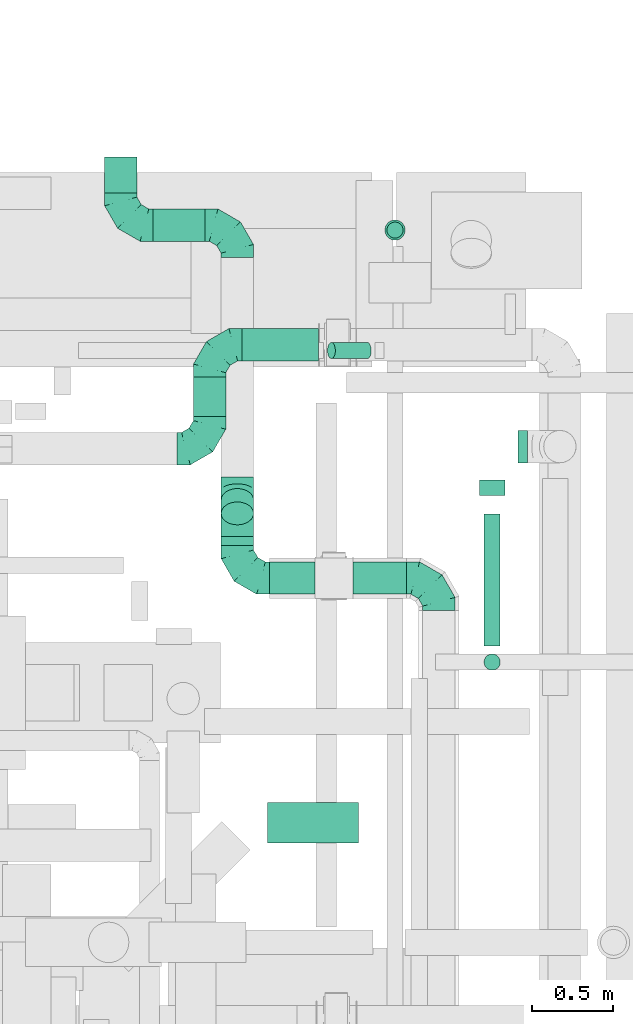
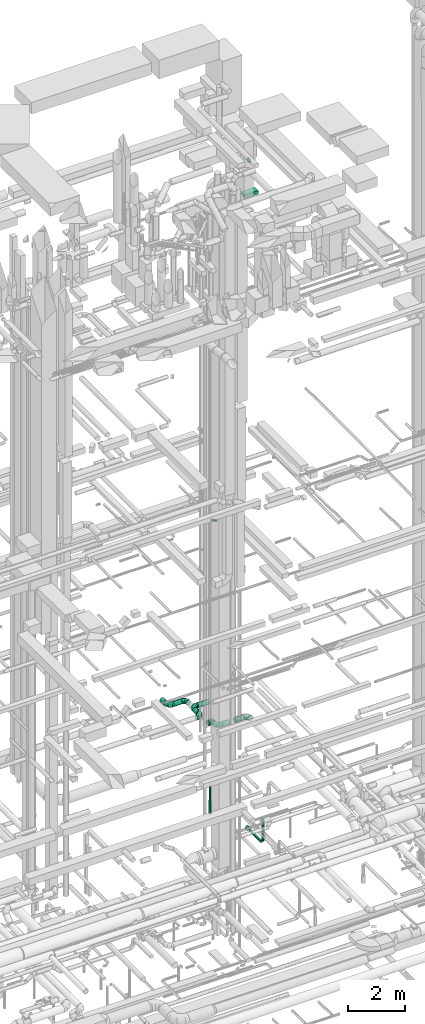
# One storey, part 292 of 337: 16 flow segments, 8 flow fittings.
"""IFC2X3 building model written with IfcOpenShell, lengths in millimetres."""

from ifc_helpers import new_model, entity, si_unit, converted_unit, derived_unit, direction, frame, origin, origin_2d_with_axis, place, context, subcontext, project, spatial, rectangle, circle, extrude, faceted_brep, source, transform, mapped, material, type_object, type_shapes, element, save


model = new_model("IFC2X3")

# Units and contexts
model_context = context("Model", 3, precision=0.01, world=origin(), true_north=direction((6.12303176911189e-17, 1.0)))
body_context = subcontext(model_context, "Body", "Model", "MODEL_VIEW")
ifc_project = project(units=[si_unit("LENGTHUNIT", "METRE", prefix="MILLI"), si_unit("AREAUNIT", "SQUARE_METRE"), si_unit("VOLUMEUNIT", "CUBIC_METRE"), converted_unit("PLANEANGLEUNIT", "DEGREE", entity("IfcRatioMeasure", 0.0174532925199433), si_unit("PLANEANGLEUNIT", "RADIAN"), dimensions=[0, 0, 0, 0, 0, 0, 0]), si_unit("MASSUNIT", "GRAM", prefix="KILO"), derived_unit("MASSDENSITYUNIT", [(si_unit("MASSUNIT", "GRAM", prefix="KILO"), 1), (si_unit("LENGTHUNIT", "METRE"), -3)]), derived_unit("MOMENTOFINERTIAUNIT", [(si_unit("LENGTHUNIT", "METRE"), 4)]), si_unit("TIMEUNIT", "SECOND"), si_unit("FREQUENCYUNIT", "HERTZ"), si_unit("THERMODYNAMICTEMPERATUREUNIT", "DEGREE_CELSIUS"), derived_unit("THERMALTRANSMITTANCEUNIT", [(si_unit("MASSUNIT", "GRAM", prefix="KILO"), 1), (si_unit("THERMODYNAMICTEMPERATUREUNIT", "KELVIN"), -1), (si_unit("TIMEUNIT", "SECOND"), -3)]), derived_unit("VOLUMETRICFLOWRATEUNIT", [(si_unit("LENGTHUNIT", "METRE"), 3), (si_unit("TIMEUNIT", "SECOND"), -1)]), derived_unit("MASSFLOWRATEUNIT", [(si_unit("MASSUNIT", "GRAM", prefix="KILO"), 1), (si_unit("TIMEUNIT", "SECOND"), -1)]), derived_unit("ROTATIONALFREQUENCYUNIT", [(si_unit("TIMEUNIT", "SECOND"), -1)]), si_unit("ELECTRICCURRENTUNIT", "AMPERE"), si_unit("ELECTRICVOLTAGEUNIT", "VOLT"), si_unit("POWERUNIT", "WATT"), si_unit("FORCEUNIT", "NEWTON", prefix="KILO"), si_unit("ILLUMINANCEUNIT", "LUX"), si_unit("LUMINOUSFLUXUNIT", "LUMEN"), si_unit("LUMINOUSINTENSITYUNIT", "CANDELA"), derived_unit("USERDEFINED", [(si_unit("MASSUNIT", "GRAM", prefix="KILO"), -1), (si_unit("LENGTHUNIT", "METRE"), -2), (si_unit("TIMEUNIT", "SECOND"), 3), (si_unit("LUMINOUSFLUXUNIT", "LUMEN"), 1)]), derived_unit("LINEARVELOCITYUNIT", [(si_unit("LENGTHUNIT", "METRE"), 1), (si_unit("TIMEUNIT", "SECOND"), -1)]), si_unit("PRESSUREUNIT", "PASCAL"), derived_unit("USERDEFINED", [(si_unit("LENGTHUNIT", "METRE"), -2), (si_unit("MASSUNIT", "GRAM", prefix="KILO"), 1), (si_unit("TIMEUNIT", "SECOND"), -2)]), derived_unit("LINEARFORCEUNIT", [(si_unit("MASSUNIT", "GRAM", prefix="KILO"), 1), (si_unit("LENGTHUNIT", "METRE"), 1), (si_unit("TIMEUNIT", "SECOND"), -2), (si_unit("LENGTHUNIT", "METRE"), -1)]), derived_unit("PLANARFORCEUNIT", [(si_unit("MASSUNIT", "GRAM", prefix="KILO"), 1), (si_unit("LENGTHUNIT", "METRE"), 1), (si_unit("TIMEUNIT", "SECOND"), -2), (si_unit("LENGTHUNIT", "METRE"), -2)])], contexts=[model_context])

# Site, building, storey
site_placement = place(None, origin())
site = spatial("IfcSite", under=ifc_project, at=site_placement, CompositionType="ELEMENT")
building_placement = place(site_placement, origin())
building = spatial("IfcBuilding", under=site, at=building_placement, CompositionType="ELEMENT")
storey_placement = place(building_placement, origin())
storey = spatial("IfcBuildingStorey", under=building, at=storey_placement, CompositionType="ELEMENT", Elevation=0.0)

# Flow segments
duct_segment_type_1 = type_object("IfcDuctSegmentType", PredefinedType="NOTDEFINED")
flow_segment_1_placement = place(storey_placement, frame((62576.39, 15963.68, 27135.0)))
element("IfcFlowSegment", 1, at=flow_segment_1_placement, inside=storey, type_object=duct_segment_type_1, context=body_context, shape_type="SweptSolid", body=[
    extrude(rectangle(XDim=561.091270347412, YDim=249.999999999999, at=origin_2d_with_axis()), frame((280.55, 125.0, 0.0)), (0.0, 0.0, 1.0), 150.000000000001),
])
duct_segment_type_2 = type_object("IfcDuctSegmentType", PredefinedType="NOTDEFINED")
flow_segment_2_placement = place(storey_placement, frame((63312.58, 19696.98, -1203.72)))
element("IfcFlowSegment", 2, at=flow_segment_2_placement, inside=storey, type_object=duct_segment_type_2, context=body_context, shape_type="SweptSolid", body=[
    extrude(circle(Radius=50.0, at=origin_2d_with_axis()), frame((51.6, 51.6, 0.0)), (0.0, 0.0, 1.0), 583.718429676785),
])
flow_segment_3_placement = place(storey_placement, frame((63300.08, 19684.48, -1800.0)))
element("IfcFlowSegment", 3, at=flow_segment_3_placement, inside=storey, type_object=duct_segment_type_2, context=body_context, shape_type="SweptSolid", body=[
    extrude(circle(Radius=62.5, at=origin_2d_with_axis()), frame((64.1, 64.1, 0.0), z_axis=(0.0, 0.0, 1.0), x_axis=(0.0, 1.0, 0.0)), (0.0, 0.0, 1.0), 549.581570323214),
])
flow_segment_4_placement = place(storey_placement, frame((63912.49, 17028.51, -1553.0)))
element("IfcFlowSegment", 4, at=flow_segment_4_placement, inside=storey, type_object=duct_segment_type_2, context=body_context, shape_type="SweptSolid", body=[
    extrude(circle(Radius=50.0, at=origin_2d_with_axis()), frame((51.6, 51.6, 0.0), z_axis=(0.0, 0.0, 1.0), x_axis=(0.0, -1.0, 0.0)), (0.0, 0.0, 1.0), 932.999999999999),
])
flow_segment_5_placement = place(storey_placement, frame((63912.49, 17180.11, -1704.6)))
element("IfcFlowSegment", 5, at=flow_segment_5_placement, inside=storey, type_object=duct_segment_type_2, context=body_context, shape_type="SweptSolid", body=[
    extrude(circle(Radius=50.0, at=origin_2d_with_axis()), frame((51.6, 0.0, 51.6), z_axis=(0.0, 1.0, 0.0), x_axis=(1.0, 0.0, 0.0)), (0.0, 0.0, 1.0), 816.003630002967),
])
flow_segment_6_placement = place(storey_placement, frame((63882.49, 18108.11, -1734.6)))
element("IfcFlowSegment", 6, at=flow_segment_6_placement, inside=storey, type_object=duct_segment_type_2, context=body_context, shape_type="SweptSolid", body=[
    extrude(circle(Radius=80.0, at=origin_2d_with_axis()), frame((81.6, 0.0, 81.6), z_axis=(0.0, 1.0, 0.0), x_axis=(1.0, 0.0, 0.0)), (0.0, 0.0, 1.0), 96.9963699970336),
])
flow_segment_7_placement = place(storey_placement, frame((62945.62, 18952.95, 11219.34)))
element("IfcFlowSegment", 7, at=flow_segment_7_placement, inside=storey, type_object=duct_segment_type_2, context=body_context, shape_type="SweptSolid", body=[
    extrude(circle(Radius=50.0, at=origin_2d_with_axis()), frame((247.36, 51.6, 45.33), z_axis=(-0.874619707139393, 0.0, 0.484809620246342), x_axis=(0.0, -1.0, 0.0)), (0.0, 0.0, 1.0), 253.276483128838),
])
flow_segment_8_placement = place(storey_placement, frame((62590.14, 17497.79, 3498.4)))
element("IfcFlowSegment", 8, at=flow_segment_8_placement, inside=storey, type_object=duct_segment_type_2, context=body_context, shape_type="SweptSolid", body=[
    extrude(circle(Radius=100.0, at=origin_2d_with_axis()), frame((0.0, 101.6, 101.6), z_axis=(1.0, 0.0, 0.0), x_axis=(0.0, 1.0, 0.0)), (0.0, 0.0, 1.0), 279.856301087674),
])
flow_segment_9_placement = place(storey_placement, frame((64122.65, 18309.88, 26648.4)))
element("IfcFlowSegment", 9, at=flow_segment_9_placement, inside=storey, type_object=duct_segment_type_2, context=body_context, shape_type="SweptSolid", body=[
    extrude(circle(Radius=100.0, at=origin_2d_with_axis()), frame((0.0, 101.6, 101.6), z_axis=(1.0, 0.0, 0.0), x_axis=(0.0, 1.0, 0.0)), (0.0, 0.0, 1.0), 60.0000000000123),
])
flow_segment_10_placement = place(storey_placement, frame((62418.88, 18939.21, 3498.4)))
element("IfcFlowSegment", 10, at=flow_segment_10_placement, inside=storey, type_object=duct_segment_type_2, context=body_context, shape_type="SweptSolid", body=[
    extrude(circle(Radius=100.0, at=origin_2d_with_axis()), frame((0.0, 101.6, 101.6), z_axis=(1.0, 0.0, 0.0), x_axis=(0.0, 1.0, 0.0)), (0.0, 0.0, 1.0), 473.615952508406),
])
flow_segment_11_placement = place(storey_placement, frame((62117.29, 18598.74, 3498.4)))
element("IfcFlowSegment", 11, at=flow_segment_11_placement, inside=storey, type_object=duct_segment_type_2, context=body_context, shape_type="SweptSolid", body=[
    extrude(circle(Radius=100.0, at=origin_2d_with_axis()), frame((101.6, 0.0, 101.6), z_axis=(0.0, 1.0, 0.0), x_axis=(-1.0, 0.0, 0.0)), (0.0, 0.0, 1.0), 242.064865424008),
])
flow_segment_12_placement = place(storey_placement, frame((62288.55, 17799.39, 3498.4)))
element("IfcFlowSegment", 12, at=flow_segment_12_placement, inside=storey, type_object=duct_segment_type_2, context=body_context, shape_type="SweptSolid", body=[
    extrude(circle(Radius=100.0, at=origin_2d_with_axis()), frame((101.6, 0.0, 101.6), z_axis=(0.0, 1.0, 0.0), x_axis=(1.0, 0.0, 0.0)), (0.0, 0.0, 1.0), 57.8773021998964),
])
flow_segment_13_placement = place(storey_placement, frame((62288.55, 17926.38, 3386.27)))
element("IfcFlowSegment", 13, at=flow_segment_13_placement, inside=storey, type_object=duct_segment_type_2, context=body_context, shape_type="SweptSolid", body=[
    extrude(circle(Radius=100.0, at=origin_2d_with_axis()), frame((101.6, 155.15, 72.31), z_axis=(0.0, -0.707106792500204, 0.707106769872891), x_axis=(1.0, 0.0, 0.0)), (0.0, 0.0, 1.0), 117.157295799914),
])
flow_segment_14_placement = place(storey_placement, frame((61870.14, 19677.79, 3298.4)))
element("IfcFlowSegment", 14, at=flow_segment_14_placement, inside=storey, type_object=duct_segment_type_2, context=body_context, shape_type="SweptSolid", body=[
    extrude(circle(Radius=100.0, at=origin_2d_with_axis()), frame((0.0, 101.6, 101.6), z_axis=(1.0, 0.0, 0.0), x_axis=(0.0, 1.0, 0.0)), (0.0, 0.0, 1.0), 319.999999999997),
])
flow_segment_15_placement = place(storey_placement, frame((61568.55, 19979.39, 3298.4)))
element("IfcFlowSegment", 15, at=flow_segment_15_placement, inside=storey, type_object=duct_segment_type_2, context=body_context, shape_type="SweptSolid", body=[
    extrude(circle(Radius=100.0, at=origin_2d_with_axis()), frame((101.6, 0.0, 101.6), z_axis=(0.0, 1.0, 0.0), x_axis=(1.0, 0.0, 0.0)), (0.0, 0.0, 1.0), 220.000000000015),
])
flow_segment_16_placement = place(storey_placement, frame((63105.0, 17497.79, 3498.4)))
element("IfcFlowSegment", 16, at=flow_segment_16_placement, inside=storey, type_object=duct_segment_type_2, context=body_context, shape_type="SweptSolid", body=[
    extrude(circle(Radius=100.0, at=origin_2d_with_axis()), frame((0.0, 101.6, 101.6), z_axis=(1.0, 0.0, 0.0), x_axis=(0.0, 1.0, 0.0)), (0.0, 0.0, 1.0), 330.444555311786),
])

# Flow fittings
ifc_material = material()
duct_fitting_type_1 = type_object("IfcDuctFittingType", PredefinedType="NOTDEFINED", material=ifc_material)
shared_shape_1 = source(origin(), body_context, "Body", "Brep", [
    faceted_brep([(-200.0, 0.0, -100.0), (-200.0, -25.88, -96.59), (-200.0, -50.0, -86.6), (-200.0, -70.71, -70.71), (-200.0, -86.6, -50.0), (-200.0, -96.59, -25.88), (-200.0, -100.0, 0.0), (-200.0, -96.59, 25.88), (-200.0, -86.6, 50.0), (-200.0, -70.71, 70.71), (-200.0, -50.0, 86.6), (-200.0, -25.88, 96.59), (-200.0, 0.0, 100.0), (-200.0, 25.88, 96.59), (-200.0, 50.0, 86.6), (-200.0, 70.71, 70.71), (-200.0, 86.6, 50.0), (-200.0, 96.59, 25.88), (-200.0, 100.0, 0.0), (-200.0, 96.59, -25.88), (-200.0, 86.6, -50.0), (-200.0, 70.71, -70.71), (-200.0, 50.0, -86.6), (-200.0, 25.88, -96.59), (-153.35, 25.88, 96.59), (-159.81, 50.0, 86.6), (-146.41, 0.0, 100.0), (-165.36, 70.71, 70.71), (-172.29, 96.59, 25.88), (-173.21, 100.0, 0.0), (-169.62, 86.6, 50.0), (-169.62, 86.6, -50.0), (-165.36, 70.71, -70.71), (-172.29, 96.59, -25.88), (-153.35, 25.88, -96.59), (-146.41, 0.0, -100.0), (-159.81, 50.0, -86.6), (-139.48, -25.88, -96.59), (-133.01, -50.0, -86.6), (-127.46, -70.71, -70.71), (-123.21, -86.6, -50.0), (-120.53, -96.59, -25.88), (-119.62, -100.0, 0.0), (-120.53, -96.59, 25.88), (-123.21, -86.6, 50.0), (-127.46, -70.71, 70.71), (-133.01, -50.0, 86.6), (-139.48, -25.88, 96.59), (-72.54, 72.54, 96.59), (-90.19, 90.19, 86.6), (-53.59, 53.59, 100.0), (-105.35, 105.35, 70.71), (-116.99, 116.99, 50.0), (-124.3, 124.3, 25.88), (-126.79, 126.79, 0.0), (-124.3, 124.3, -25.88), (-116.99, 116.99, -50.0), (-105.35, 105.35, -70.71), (-72.54, 72.54, -96.59), (-53.59, 53.59, -100.0), (-90.19, 90.19, -86.6), (-34.64, 34.64, -96.59), (-16.99, 16.99, -86.6), (-1.83, 1.83, -70.71), (9.81, -9.81, -50.0), (17.12, -17.12, -25.88), (19.62, -19.62, 0.0), (17.12, -17.12, 25.88), (9.81, -9.81, 50.0), (-1.83, 1.83, 70.71), (-16.99, 16.99, 86.6), (-34.64, 34.64, 96.59), (-25.88, 153.35, 96.59), (-50.0, 159.81, 86.6), (0.0, 146.41, 100.0), (-70.71, 165.36, 70.71), (-86.6, 169.62, 50.0), (-96.59, 172.29, 25.88), (-100.0, 173.21, 0.0), (-96.59, 172.29, -25.88), (-86.6, 169.62, -50.0), (-70.71, 165.36, -70.71), (-25.88, 153.35, -96.59), (0.0, 146.41, -100.0), (-50.0, 159.81, -86.6), (25.88, 139.48, -96.59), (50.0, 133.01, -86.6), (70.71, 127.46, -70.71), (86.6, 123.21, -50.0), (96.59, 120.53, -25.88), (100.0, 119.62, 0.0), (96.59, 120.53, 25.88), (86.6, 123.21, 50.0), (70.71, 127.46, 70.71), (50.0, 133.01, 86.6), (25.88, 139.48, 96.59), (-25.88, 200.0, -96.59), (-50.0, 200.0, -86.6), (-70.71, 200.0, -70.71), (-86.6, 200.0, -50.0), (-96.59, 200.0, -25.88), (-100.0, 200.0, 0.0), (-96.59, 200.0, 25.88), (-86.6, 200.0, 50.0), (-70.71, 200.0, 70.71), (-50.0, 200.0, 86.6), (-25.88, 200.0, 96.59), (0.0, 200.0, 100.0), (25.88, 200.0, 96.59), (50.0, 200.0, 86.6), (70.71, 200.0, 70.71), (86.6, 200.0, 50.0), (96.59, 200.0, 25.88), (100.0, 200.0, 0.0), (96.59, 200.0, -25.88), (86.6, 200.0, -50.0), (70.71, 200.0, -70.71), (50.0, 200.0, -86.6), (25.88, 200.0, -96.59), (0.0, 200.0, -100.0)], [[[0, 1, 2, 3, 4, 5, 6, 7, 8, 9, 10, 11, 12, 13, 14, 15, 16, 17, 18, 19, 20, 21, 22, 23]], [[24, 25, 14, 13]], [[26, 24, 13, 12]], [[14, 25, 27, 15]], [[28, 29, 18, 17]], [[30, 28, 17, 16]], [[15, 27, 30, 16]], [[20, 31, 32, 21]], [[33, 31, 20, 19]], [[18, 29, 33, 19]], [[34, 35, 0, 23]], [[36, 34, 23, 22]], [[32, 36, 22, 21]], [[1, 0, 35, 37]], [[2, 1, 37, 38]], [[38, 39, 3, 2]], [[5, 4, 40, 41]], [[6, 5, 41, 42]], [[39, 40, 4, 3]], [[6, 42, 43, 7]], [[7, 43, 44, 8]], [[8, 44, 45, 9]], [[9, 45, 46, 10]], [[10, 46, 47, 11]], [[26, 12, 11, 47]], [[48, 49, 25, 24]], [[50, 48, 24, 26]], [[27, 25, 49, 51]], [[52, 53, 28, 30]], [[51, 52, 30, 27]], [[29, 28, 53, 54]], [[55, 56, 31, 33]], [[54, 55, 33, 29]], [[32, 31, 56, 57]], [[58, 59, 35, 34]], [[60, 58, 34, 36]], [[57, 60, 36, 32]], [[37, 35, 59, 61]], [[38, 37, 61, 62]], [[39, 38, 62, 63]], [[41, 40, 64, 65]], [[42, 41, 65, 66]], [[63, 64, 40, 39]], [[43, 42, 66, 67]], [[44, 43, 67, 68]], [[68, 69, 45, 44]], [[46, 45, 69, 70]], [[47, 46, 70, 71]], [[26, 47, 71, 50]], [[72, 73, 49, 48]], [[74, 72, 48, 50]], [[51, 49, 73, 75]], [[76, 77, 53, 52]], [[75, 76, 52, 51]], [[54, 53, 77, 78]], [[79, 80, 56, 55]], [[78, 79, 55, 54]], [[57, 56, 80, 81]], [[82, 83, 59, 58]], [[84, 82, 58, 60]], [[81, 84, 60, 57]], [[61, 59, 83, 85]], [[62, 61, 85, 86]], [[63, 62, 86, 87]], [[65, 64, 88, 89]], [[66, 65, 89, 90]], [[87, 88, 64, 63]], [[67, 66, 90, 91]], [[68, 67, 91, 92]], [[92, 93, 69, 68]], [[70, 69, 93, 94]], [[71, 70, 94, 95]], [[50, 71, 95, 74]], [[96, 97, 98, 99, 100, 101, 102, 103, 104, 105, 106, 107, 108, 109, 110, 111, 112, 113, 114, 115, 116, 117, 118, 119]], [[72, 74, 107, 106]], [[73, 72, 106, 105]], [[75, 73, 105, 104]], [[102, 101, 78, 77]], [[103, 102, 77, 76]], [[75, 104, 103, 76]], [[78, 101, 100, 79]], [[79, 100, 99, 80]], [[80, 99, 98, 81]], [[84, 97, 96, 82]], [[82, 96, 119, 83]], [[84, 81, 98, 97]], [[118, 117, 86, 85]], [[119, 118, 85, 83]], [[116, 87, 86, 117]], [[88, 115, 114, 89]], [[89, 114, 113, 90]], [[115, 88, 87, 116]], [[91, 90, 113, 112]], [[92, 91, 112, 111]], [[111, 110, 93, 92]], [[95, 94, 109, 108]], [[74, 95, 108, 107]], [[110, 109, 94, 93]]]),
])
type_shapes(duct_fitting_type_1, [shared_shape_1])
for number, where, z_axis, x_axis in (
    (17, (63635.44, 17599.39, 3600.0), (0.0, 0.0, 1.0), (0.0, 1.0, 0.0)),
    (18, (62218.88, 19040.8, 3600.0), (0.0, 0.0, 1.0), (-1.0, 0.0, 0.0)),
):
    element("IfcFlowFitting", number, at=place(storey_placement, frame(where, z_axis=z_axis, x_axis=x_axis)), inside=storey, type_object=duct_fitting_type_1, material=ifc_material, context=body_context, shape_type="MappedRepresentation", body=[
        mapped(shared_shape_1, transform((0.0, 0.0, 0.0), scale=1.0)),
    ])
flow_fitting_placement = place(storey_placement, frame((62218.88, 18398.74, 3600.0)))
element("IfcFlowFitting", 19, at=flow_fitting_placement, inside=storey, type_object=duct_fitting_type_1, material=ifc_material, context=body_context, shape_type="MappedRepresentation", body=[
    mapped(shared_shape_1, transform((0.0, 0.0, 0.0), scale=1.0)),
])
for number, where, z_axis, x_axis in (
    (20, (62390.14, 17599.39, 3600.0), (0.0, 0.0, 1.0), (0.0, -1.0, 0.0)),
    (21, (62390.14, 19779.39, 3400.0), (0.0, 0.0, 1.0), (0.0, 1.0, 0.0)),
    (22, (61670.14, 19779.39, 3400.0), (0.0, 0.0, 1.0), (0.0, -1.0, 0.0)),
):
    element("IfcFlowFitting", number, at=place(storey_placement, frame(where, z_axis=z_axis, x_axis=x_axis)), inside=storey, type_object=duct_fitting_type_1, material=ifc_material, context=body_context, shape_type="MappedRepresentation", body=[
        mapped(shared_shape_1, transform((0.0, 0.0, 0.0), scale=1.0)),
    ])
duct_fitting_type_2 = type_object("IfcDuctFittingType", PredefinedType="NOTDEFINED", material=ifc_material)
shared_shape_2 = source(origin(), body_context, "Body", "Brep", [
    faceted_brep([(-82.84, 0.0, -100.0), (-82.84, -25.88, -96.59), (-82.84, -50.0, -86.6), (-82.84, -70.71, -70.71), (-82.84, -86.6, -50.0), (-82.84, -96.59, -25.88), (-82.84, -100.0, 0.0), (-82.84, -96.59, 25.88), (-82.84, -86.6, 50.0), (-82.84, -70.71, 70.71), (-82.84, -50.0, 86.6), (-82.84, -25.88, 96.59), (-82.84, 0.0, 100.0), (-82.84, 25.88, 96.59), (-82.84, 50.0, 86.6), (-82.84, 70.71, 70.71), (-82.84, 86.6, 50.0), (-82.84, 96.59, 25.88), (-82.84, 100.0, 0.0), (-82.84, 96.59, -25.88), (-82.84, 86.6, -50.0), (-82.84, 70.71, -70.71), (-82.84, 50.0, -86.6), (-82.84, 25.88, -96.59), (-10.72, 25.88, 96.59), (-20.71, 50.0, 86.6), (0.0, 0.0, 100.0), (-29.29, 70.71, 70.71), (-35.87, 86.6, 50.0), (-40.01, 96.59, 25.88), (-41.42, 100.0, 0.0), (-40.01, 96.59, -25.88), (-35.87, 86.6, -50.0), (-29.29, 70.71, -70.71), (-10.72, 25.88, -96.59), (0.0, 0.0, -100.0), (-20.71, 50.0, -86.6), (10.72, -25.88, -96.59), (20.71, -50.0, -86.6), (29.29, -70.71, -70.71), (35.87, -86.6, -50.0), (40.01, -96.59, -25.88), (41.42, -100.0, 0.0), (40.01, -96.59, 25.88), (35.87, -86.6, 50.0), (29.29, -70.71, 70.71), (20.71, -50.0, 86.6), (10.72, -25.88, 96.59), (58.58, 58.58, 100.0), (40.28, 76.88, 96.59), (23.22, 93.93, 86.6), (8.58, 108.58, 70.71), (-2.66, 119.82, 50.0), (-9.72, 126.88, 25.88), (-12.13, 129.29, 0.0), (-9.72, 126.88, -25.88), (-2.66, 119.82, -50.0), (8.58, 108.58, -70.71), (23.22, 93.93, -86.6), (40.28, 76.88, -96.59), (58.58, 58.58, -100.0), (76.88, 40.28, -96.59), (93.93, 23.22, -86.6), (108.58, 8.58, -70.71), (119.82, -2.66, -50.0), (126.88, -9.72, -25.88), (129.29, -12.13, 0.0), (126.88, -9.72, 25.88), (119.82, -2.66, 50.0), (108.58, 8.58, 70.71), (93.93, 23.22, 86.6), (76.88, 40.28, 96.59)], [[[0, 1, 2, 3, 4, 5, 6, 7, 8, 9, 10, 11, 12, 13, 14, 15, 16, 17, 18, 19, 20, 21, 22, 23]], [[24, 25, 14, 13]], [[26, 24, 13, 12]], [[14, 25, 27, 15]], [[28, 29, 17, 16]], [[28, 16, 15, 27]], [[30, 18, 17, 29]], [[31, 32, 20, 19]], [[30, 31, 19, 18]], [[32, 33, 21, 20]], [[34, 35, 0, 23]], [[36, 34, 23, 22]], [[33, 36, 22, 21]], [[1, 0, 35, 37]], [[2, 1, 37, 38]], [[38, 39, 3, 2]], [[5, 4, 40, 41]], [[6, 5, 41, 42]], [[39, 40, 4, 3]], [[6, 42, 43, 7]], [[7, 43, 44, 8]], [[8, 44, 45, 9]], [[9, 45, 46, 10]], [[10, 46, 47, 11]], [[26, 12, 11, 47]], [[24, 26, 48, 49]], [[25, 24, 49, 50]], [[27, 25, 50, 51]], [[29, 28, 52, 53]], [[30, 29, 53, 54]], [[51, 52, 28, 27]], [[30, 54, 55, 31]], [[31, 55, 56, 32]], [[57, 33, 32, 56]], [[36, 58, 59, 34]], [[34, 59, 60, 35]], [[58, 36, 33, 57]], [[35, 60, 61, 37]], [[37, 61, 62, 38]], [[63, 39, 38, 62]], [[40, 64, 65, 41]], [[41, 65, 66, 42]], [[64, 40, 39, 63]], [[43, 42, 66, 67]], [[44, 43, 67, 68]], [[68, 69, 45, 44]], [[47, 46, 70, 71]], [[26, 47, 71, 48]], [[69, 70, 46, 45]], [[59, 58, 57, 56, 55, 54, 53, 52, 51, 50, 49, 48, 71, 70, 69, 68, 67, 66, 65, 64, 63, 62, 61, 60]]]),
])
type_shapes(duct_fitting_type_2, [shared_shape_2])
for number, where, z_axis, x_axis in (
    (23, (62390.14, 17940.11, 3600.0), (-1.0, 0.0, 0.0), (0.0, 1.0, 0.0)),
    (24, (62390.14, 18140.11, 3400.0), (1.0, 0.0, 0.0), (0.0, 0.707106792500203, -0.707106769872892)),
):
    element("IfcFlowFitting", number, at=place(storey_placement, frame(where, z_axis=z_axis, x_axis=x_axis)), inside=storey, type_object=duct_fitting_type_2, material=ifc_material, context=body_context, shape_type="MappedRepresentation", body=[
        mapped(shared_shape_2, transform((0.0, 0.0, 0.0), scale=1.0)),
    ])

save(model, "model.ifc")
